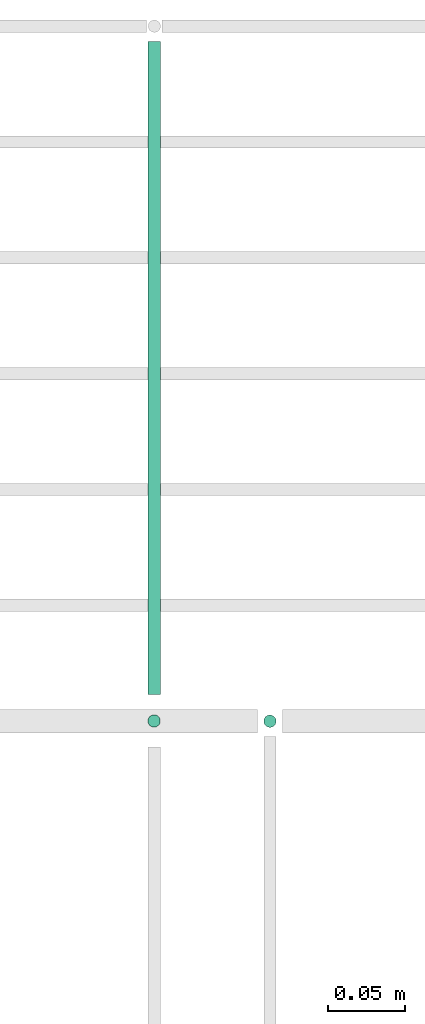
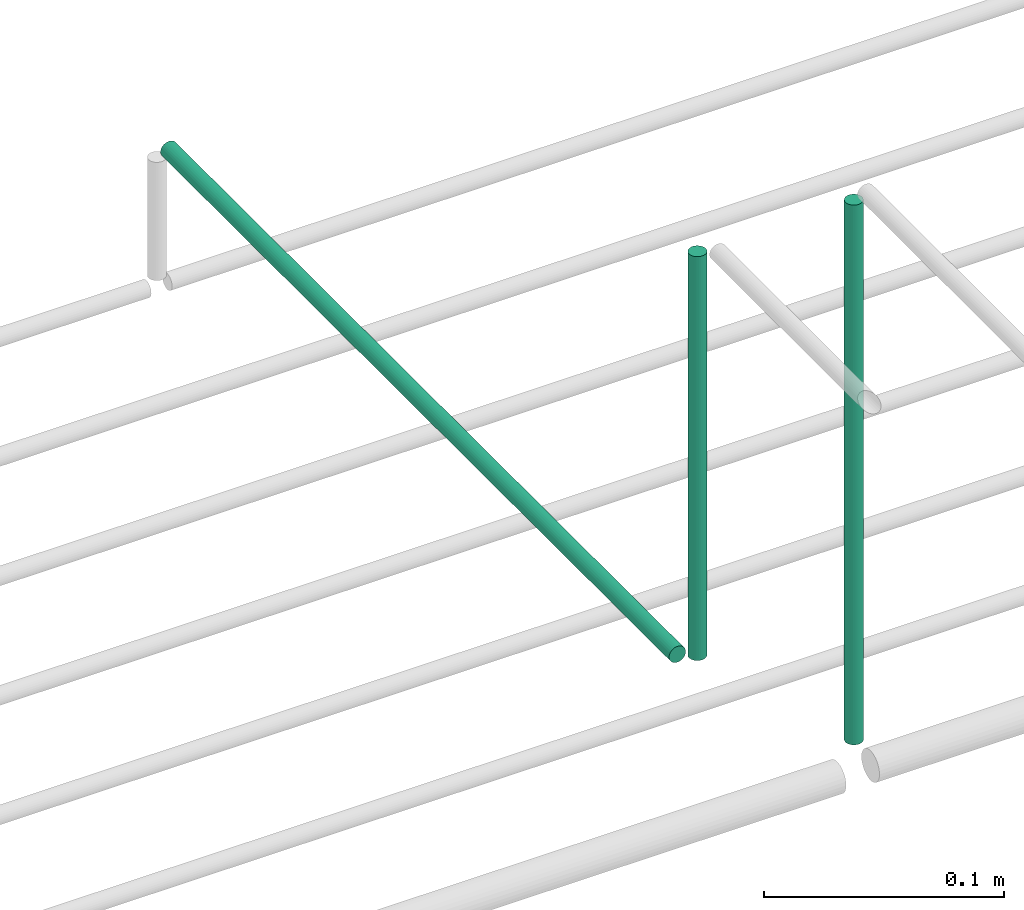
# One storey, part 45 of 89: 3 flow segments.
"""IFC2X3 building model written with IfcOpenShell, lengths in millimetres."""

from ifc_helpers import new_model, entity, si_unit, converted_unit, derived_unit, direction, frame, origin, origin_2d_with_axis, place, context, subcontext, project, spatial, circle, extrude, type_object, element, save


model = new_model("IFC2X3")

# Units and contexts
model_context = context("Model", 3, precision=0.01, world=origin(), true_north=direction((6.12303176911189e-17, 1.0)))
body_context = subcontext(model_context, "Body", "Model", "MODEL_VIEW")
ifc_project = project(units=[si_unit("LENGTHUNIT", "METRE", prefix="MILLI"), si_unit("AREAUNIT", "SQUARE_METRE"), si_unit("VOLUMEUNIT", "CUBIC_METRE"), converted_unit("PLANEANGLEUNIT", "DEGREE", entity("IfcRatioMeasure", 0.0174532925199433), si_unit("PLANEANGLEUNIT", "RADIAN"), dimensions=[0, 0, 0, 0, 0, 0, 0]), si_unit("MASSUNIT", "GRAM", prefix="KILO"), derived_unit("MASSDENSITYUNIT", [(si_unit("MASSUNIT", "GRAM", prefix="KILO"), 1), (si_unit("LENGTHUNIT", "METRE"), -3)]), derived_unit("MOMENTOFINERTIAUNIT", [(si_unit("LENGTHUNIT", "METRE"), 4)]), si_unit("TIMEUNIT", "SECOND"), si_unit("FREQUENCYUNIT", "HERTZ"), si_unit("THERMODYNAMICTEMPERATUREUNIT", "DEGREE_CELSIUS"), derived_unit("THERMALTRANSMITTANCEUNIT", [(si_unit("MASSUNIT", "GRAM", prefix="KILO"), 1), (si_unit("THERMODYNAMICTEMPERATUREUNIT", "KELVIN"), -1), (si_unit("TIMEUNIT", "SECOND"), -3)]), derived_unit("VOLUMETRICFLOWRATEUNIT", [(si_unit("LENGTHUNIT", "METRE"), 3), (si_unit("TIMEUNIT", "SECOND"), -1)]), derived_unit("MASSFLOWRATEUNIT", [(si_unit("MASSUNIT", "GRAM", prefix="KILO"), 1), (si_unit("TIMEUNIT", "SECOND"), -1)]), derived_unit("ROTATIONALFREQUENCYUNIT", [(si_unit("TIMEUNIT", "SECOND"), -1)]), si_unit("ELECTRICCURRENTUNIT", "AMPERE"), si_unit("ELECTRICVOLTAGEUNIT", "VOLT"), si_unit("POWERUNIT", "WATT"), si_unit("FORCEUNIT", "NEWTON", prefix="KILO"), si_unit("ILLUMINANCEUNIT", "LUX"), si_unit("LUMINOUSFLUXUNIT", "LUMEN"), si_unit("LUMINOUSINTENSITYUNIT", "CANDELA"), derived_unit("USERDEFINED", [(si_unit("MASSUNIT", "GRAM", prefix="KILO"), -1), (si_unit("LENGTHUNIT", "METRE"), -2), (si_unit("TIMEUNIT", "SECOND"), 3), (si_unit("LUMINOUSFLUXUNIT", "LUMEN"), 1)]), derived_unit("LINEARVELOCITYUNIT", [(si_unit("LENGTHUNIT", "METRE"), 1), (si_unit("TIMEUNIT", "SECOND"), -1)]), si_unit("PRESSUREUNIT", "PASCAL"), derived_unit("USERDEFINED", [(si_unit("LENGTHUNIT", "METRE"), -2), (si_unit("MASSUNIT", "GRAM", prefix="KILO"), 1), (si_unit("TIMEUNIT", "SECOND"), -2)]), derived_unit("LINEARFORCEUNIT", [(si_unit("MASSUNIT", "GRAM", prefix="KILO"), 1), (si_unit("LENGTHUNIT", "METRE"), 1), (si_unit("TIMEUNIT", "SECOND"), -2), (si_unit("LENGTHUNIT", "METRE"), -1)]), derived_unit("PLANARFORCEUNIT", [(si_unit("MASSUNIT", "GRAM", prefix="KILO"), 1), (si_unit("LENGTHUNIT", "METRE"), 1), (si_unit("TIMEUNIT", "SECOND"), -2), (si_unit("LENGTHUNIT", "METRE"), -2)])], contexts=[model_context])

# Site, building, storey
site_placement = place(None, frame((0.0, -0.00077364408347762, 0.0)))
site = spatial("IfcSite", under=ifc_project, at=site_placement, CompositionType="ELEMENT")
building_placement = place(site_placement, origin())
building = spatial("IfcBuilding", under=site, at=building_placement, CompositionType="ELEMENT")
storey_placement = place(building_placement, frame((0.0, 0.0, 24000.0)))
storey = spatial("IfcBuildingStorey", under=building, at=storey_placement, CompositionType="ELEMENT", Elevation=24000.0)

# Flow segments
pipe_segment_type = type_object("IfcPipeSegmentType", PredefinedType="NOTDEFINED")
flow_segment_1_placement = place(storey_placement, frame((48815.5947989665, 18644.4047277641, 2791.0)))
element("IfcFlowSegment", 1, at=flow_segment_1_placement, inside=storey, type_object=pipe_segment_type, context=body_context, shape_type="SweptSolid", body=[
    extrude(circle(Radius=4.0, at=origin_2d_with_axis()), frame((5.59527223591499, 5.59527223591499, 0.0), z_axis=(0.0, 0.0, 1.0), x_axis=(-1.0, 0.0, 0.0)), (0.0, 0.0, 1.0), 273.99999999999),
])
flow_segment_2_placement = place(storey_placement, frame((48740.5691665632, 18644.5582806599, 2859.99965095085)))
element("IfcFlowSegment", 2, at=flow_segment_2_placement, inside=storey, type_object=pipe_segment_type, context=body_context, shape_type="SweptSolid", body=[
    extrude(circle(Radius=4.0, at=origin_2d_with_axis()), frame((5.5952722206509, 5.59527223591499, 0.000349592837017099), z_axis=(8.73982106718787e-05, 0.0, 0.999999996180776), x_axis=(0.999999996180776, 0.0, -8.73982106718787e-05)), (0.0, 0.0, 1.0), 205.000000850331),
])
flow_segment_3_placement = place(storey_placement, frame((48740.7777471211, 18667.1535528394, 2844.4047316051)))
element("IfcFlowSegment", 3, at=flow_segment_3_placement, inside=storey, type_object=pipe_segment_type, context=body_context, shape_type="SweptSolid", body=[
    extrude(circle(Radius=4.0, at=origin_2d_with_axis()), frame((5.59527223591499, 0.0, 5.59527223591499), z_axis=(0.0, 1.0, 0.0), x_axis=(-1.0, 0.0, 0.0)), (0.0, 0.0, 1.0), 422.846447160737),
])

save(model, "model.ifc")
